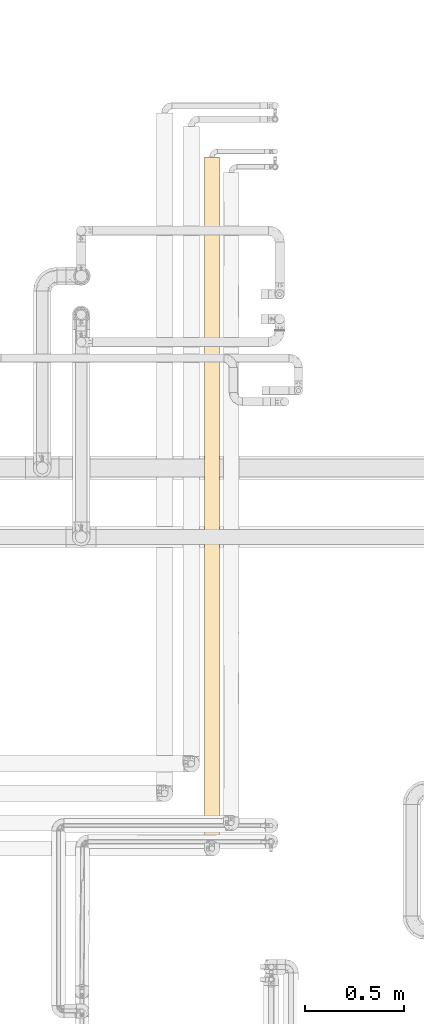
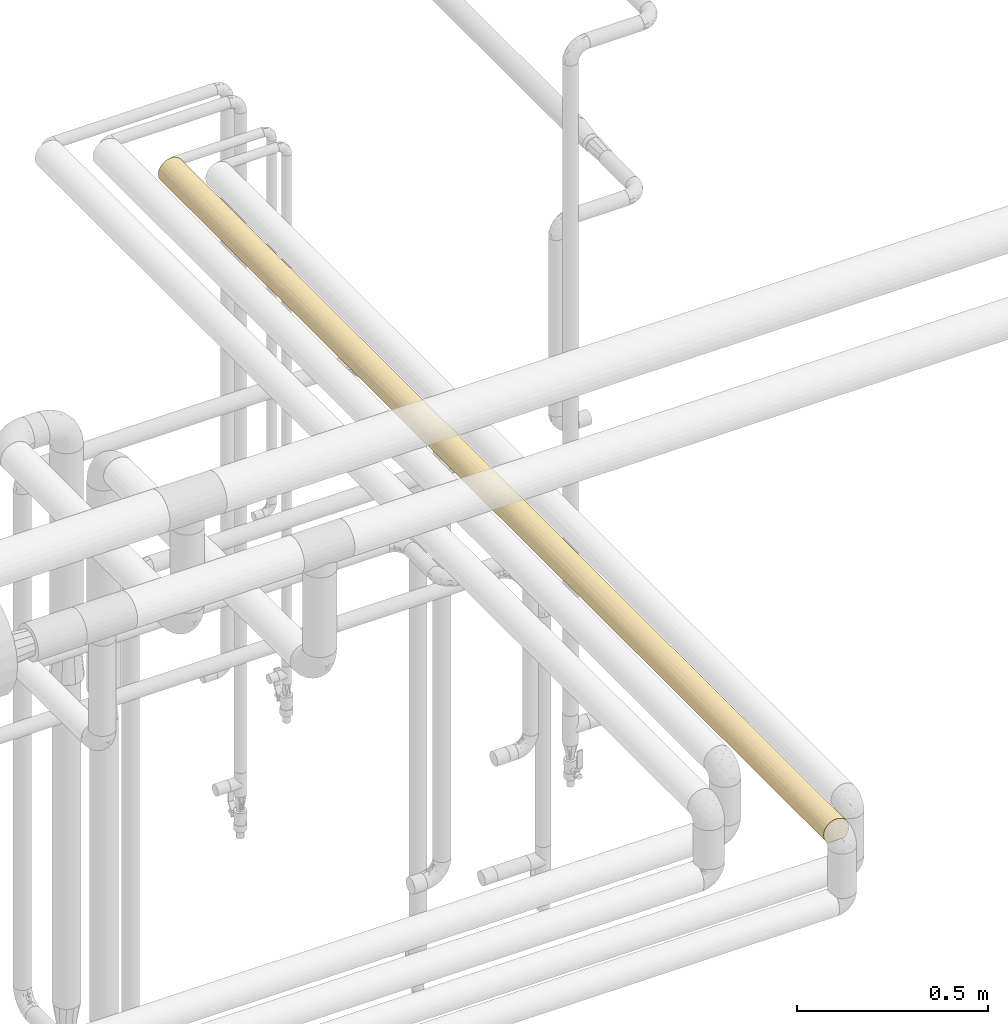
# One storey, part 35 of 827: 1 covering.
"""IFC2X3 building model written with IfcOpenShell, lengths in millimetres."""

from ifc_helpers import new_model, entity, si_unit, converted_unit, derived_unit, direction, frame, origin, place, context, subcontext, project, spatial, faceted_brep, element, save


model = new_model("IFC2X3")

# Units and contexts
model_context = context("Model", 3, precision=0.01, world=origin(), true_north=direction((6.12303176911189e-17, 1.0)))
body_context = subcontext(model_context, "Body", "Model", "MODEL_VIEW")
ifc_project = project(units=[si_unit("LENGTHUNIT", "METRE", prefix="MILLI"), si_unit("AREAUNIT", "SQUARE_METRE"), si_unit("VOLUMEUNIT", "CUBIC_METRE"), converted_unit("PLANEANGLEUNIT", "DEGREE", entity("IfcRatioMeasure", 0.0174532925199433), si_unit("PLANEANGLEUNIT", "RADIAN"), dimensions=[0, 0, 0, 0, 0, 0, 0]), si_unit("MASSUNIT", "GRAM", prefix="KILO"), derived_unit("MASSDENSITYUNIT", [(si_unit("MASSUNIT", "GRAM", prefix="KILO"), 1), (si_unit("LENGTHUNIT", "METRE"), -3)]), derived_unit("MOMENTOFINERTIAUNIT", [(si_unit("LENGTHUNIT", "METRE"), 4)]), si_unit("TIMEUNIT", "SECOND"), si_unit("FREQUENCYUNIT", "HERTZ"), si_unit("THERMODYNAMICTEMPERATUREUNIT", "DEGREE_CELSIUS"), derived_unit("THERMALTRANSMITTANCEUNIT", [(si_unit("MASSUNIT", "GRAM", prefix="KILO"), 1), (si_unit("THERMODYNAMICTEMPERATUREUNIT", "KELVIN"), -1), (si_unit("TIMEUNIT", "SECOND"), -3)]), derived_unit("VOLUMETRICFLOWRATEUNIT", [(si_unit("LENGTHUNIT", "METRE"), 3), (si_unit("TIMEUNIT", "SECOND"), -1)]), derived_unit("MASSFLOWRATEUNIT", [(si_unit("MASSUNIT", "GRAM", prefix="KILO"), 1), (si_unit("TIMEUNIT", "SECOND"), -1)]), derived_unit("ROTATIONALFREQUENCYUNIT", [(si_unit("TIMEUNIT", "SECOND"), -1)]), si_unit("ELECTRICCURRENTUNIT", "AMPERE"), si_unit("ELECTRICVOLTAGEUNIT", "VOLT"), si_unit("POWERUNIT", "WATT"), si_unit("FORCEUNIT", "NEWTON", prefix="KILO"), si_unit("ILLUMINANCEUNIT", "LUX"), si_unit("LUMINOUSFLUXUNIT", "LUMEN"), si_unit("LUMINOUSINTENSITYUNIT", "CANDELA"), derived_unit("USERDEFINED", [(si_unit("MASSUNIT", "GRAM", prefix="KILO"), -1), (si_unit("LENGTHUNIT", "METRE"), -2), (si_unit("TIMEUNIT", "SECOND"), 3), (si_unit("LUMINOUSFLUXUNIT", "LUMEN"), 1)]), derived_unit("LINEARVELOCITYUNIT", [(si_unit("LENGTHUNIT", "METRE"), 1), (si_unit("TIMEUNIT", "SECOND"), -1)]), si_unit("PRESSUREUNIT", "PASCAL"), derived_unit("USERDEFINED", [(si_unit("LENGTHUNIT", "METRE"), -2), (si_unit("MASSUNIT", "GRAM", prefix="KILO"), 1), (si_unit("TIMEUNIT", "SECOND"), -2)]), derived_unit("LINEARFORCEUNIT", [(si_unit("MASSUNIT", "GRAM", prefix="KILO"), 1), (si_unit("LENGTHUNIT", "METRE"), 1), (si_unit("TIMEUNIT", "SECOND"), -2), (si_unit("LENGTHUNIT", "METRE"), -1)]), derived_unit("PLANARFORCEUNIT", [(si_unit("MASSUNIT", "GRAM", prefix="KILO"), 1), (si_unit("LENGTHUNIT", "METRE"), 1), (si_unit("TIMEUNIT", "SECOND"), -2), (si_unit("LENGTHUNIT", "METRE"), -2)])], contexts=[model_context])

# Site, building, storey
site_placement = place(None, origin())
site = spatial("IfcSite", under=ifc_project, at=site_placement, CompositionType="ELEMENT")
building_placement = place(site_placement, origin())
building = spatial("IfcBuilding", under=site, at=building_placement, CompositionType="ELEMENT")
storey_placement = place(building_placement, frame((0.0, 0.0, 28200.0)))
storey = spatial("IfcBuildingStorey", under=building, at=storey_placement, Name="08", CompositionType="ELEMENT", Elevation=28200.0)

# Covering
covering_placement = place(storey_placement, frame((18545.56, 12847.5, 2560.0)))
element("IfcCovering", 1, at=covering_placement, inside=storey, Name=":ADSK_", ObjectType=":ADSK_", PredefinedType="INSULATION", context=body_context, shape_type="Brep", body=[
    faceted_brep([(2.48, 1.6, 31.79), (5.09, 1.6, 23.98), (9.31, 1.6, 16.91), (14.94, 1.6, 10.9), (65.05, 1.6, 10.9), (70.68, 1.6, 16.91), (74.9, 1.6, 23.98), (77.51, 1.6, 31.79), (78.4, 1.6, 40.0), (77.09, 1.6, 49.93), (73.25, 1.6, 59.2), (67.15, 1.6, 67.15), (59.2, 1.6, 73.25), (49.93, 1.6, 77.09), (40.0, 1.6, 78.4), (30.06, 1.6, 77.09), (20.8, 1.6, 73.25), (12.84, 1.6, 67.15), (6.74, 1.6, 59.2), (2.9, 1.6, 49.93), (1.6, 1.6, 40.0), (20.8, 3478.3, 6.74), (12.84, 3478.3, 12.84), (6.74, 3478.3, 20.8), (2.9, 3478.3, 30.06), (1.6, 3478.3, 40.0), (2.9, 3478.3, 49.93), (6.74, 3478.3, 59.2), (12.84, 3478.3, 67.15), (20.8, 3478.3, 73.25), (30.06, 3478.3, 77.09), (40.0, 3478.3, 78.4), (49.93, 3478.3, 77.09), (59.2, 3478.3, 73.25), (67.15, 3478.3, 67.15), (73.25, 3478.3, 59.2), (77.09, 3478.3, 49.93), (78.4, 3478.3, 40.0), (77.09, 3478.3, 30.06), (73.25, 3478.3, 20.8), (67.15, 3478.3, 12.84), (59.2, 3478.3, 6.74), (49.93, 3478.3, 2.9), (40.0, 3478.3, 1.6), (30.06, 3478.3, 2.9), (9.53, 3219.11, 16.62), (3.58, 287.23, 27.82), (7.01, 218.66, 20.33), (9.53, 2754.64, 16.62), (17.76, 2708.4, 8.69), (17.36, 2482.89, 8.98), (2.29, 3153.74, 32.71), (2.42, 2856.65, 32.07), (1.6, 3045.56, 40.0), (11.96, 287.24, 13.75), (27.09, 1963.43, 3.83), (28.96, 2162.99, 3.21), (32.97, 1853.13, 2.24), (7.01, 485.18, 20.33), (15.06, 491.88, 10.8), (25.3, 3233.25, 4.52), (11.39, 914.92, 14.37), (10.86, 658.66, 14.98), (6.04, 783.02, 22.06), (3.89, 3283.65, 26.92), (4.52, 3072.98, 25.3), (22.88, 606.06, 5.62), (23.76, 835.17, 5.2), (29.53, 688.07, 3.05), (2.85, 616.82, 30.25), (1.6, 217.97, 40.0), (40.0, 3261.93, 1.6), (40.0, 660.01, 1.6), (40.0, 443.64, 1.6), (40.0, 876.39, 1.6), (23.31, 384.99, 5.41), (26.63, 8.5, 4.0), (20.48, 5.57, 6.92), (24.03, 2447.85, 5.07), (32.57, 2467.59, 2.32), (32.19, 1223.7, 2.4), (40.0, 1093.44, 1.6), (28.94, 1001.34, 3.22), (32.71, 3153.74, 2.29), (25.3, 2948.59, 4.52), (31.75, 335.45, 2.49), (33.21, 10.29, 2.2), (17.51, 298.24, 8.87), (16.62, 3154.03, 9.53), (4.86, 2721.19, 24.5), (40.0, 227.27, 1.6), (40.0, 10.9, 1.6), (33.12, 2916.66, 2.22), (28.05, 2689.88, 3.5), (1.6, 3261.93, 40.0), (1.6, 434.34, 40.0), (17.38, 2931.84, 8.96), (7.28, 2941.54, 19.89), (11.76, 2986.88, 13.97), (2.9, 953.6, 30.08), (1.6, 1083.46, 40.0), (3.06, 1262.09, 29.49), (2.54, 2622.2, 31.51), (25.08, 1521.26, 4.61), (32.66, 1590.99, 2.3), (17.22, 717.19, 9.08), (6.49, 1362.64, 21.23), (3.48, 1624.39, 28.11), (6.45, 1670.45, 21.3), (6.41, 1085.46, 21.37), (12.45, 1245.73, 13.24), (1.6, 867.09, 40.0), (1.6, 650.71, 40.0), (40.0, 2612.81, 1.6), (40.0, 3045.56, 1.6), (40.0, 2829.18, 1.6), (40.0, 1961.65, 1.6), (22.04, 2116.57, 6.05), (12.14, 2378.34, 13.56), (16.28, 2019.25, 9.79), (9.05, 1840.27, 17.25), (9.42, 2122.62, 16.76), (7.4, 2369.94, 19.69), (15.3, 1744.72, 10.59), (2.38, 2282.72, 32.28), (4.17, 2451.09, 26.17), (4.68, 2224.01, 24.92), (2.29, 2025.52, 32.71), (1.6, 2172.7, 40.0), (25.96, 1758.89, 4.25), (1.6, 2392.75, 40.0), (1.6, 2396.44, 40.0), (1.6, 2612.81, 40.0), (1.6, 2829.18, 40.0), (1.6, 1516.21, 40.0), (40.0, 2395.76, 1.6), (40.0, 2395.08, 1.6), (40.0, 2178.71, 1.6), (40.0, 1959.61, 1.6), (40.0, 1744.6, 1.6), (24.44, 1282.91, 4.89), (18.12, 1234.93, 8.44), (17.51, 1479.79, 8.87), (1.6, 1527.26, 40.0), (1.6, 1732.58, 40.0), (1.6, 1087.14, 40.0), (1.6, 1299.83, 40.0), (1.6, 1307.2, 40.0), (19.12, 1023.05, 7.77), (10.19, 1564.74, 15.79), (3.17, 1838.1, 29.1), (1.6, 1747.32, 40.0), (1.6, 1952.64, 40.0), (4.96, 1994.53, 24.27), (1.6, 2180.06, 40.0), (1.6, 1963.69, 40.0), (40.0, 2177.35, 1.6), (40.0, 1741.88, 1.6), (40.0, 1527.55, 1.6), (40.0, 1525.51, 1.6), (40.0, 1310.49, 1.6), (40.0, 1092.76, 1.6), (40.0, 1309.13, 1.6), (75.47, 3233.25, 25.3), (50.46, 688.07, 3.05), (51.05, 1001.34, 3.22), (56.23, 835.17, 5.2), (63.37, 3219.11, 9.53), (72.98, 218.66, 20.33), (72.98, 485.18, 20.33), (69.13, 658.66, 14.98), (73.95, 783.02, 22.06), (76.06, 1504.87, 26.81), (76.79, 1232.32, 29.01), (73.89, 1322.89, 21.95), (56.19, 2734.63, 5.18), (60.1, 2941.54, 7.28), (63.37, 2754.64, 9.53), (47.79, 1755.35, 2.39), (58.31, 1653.16, 6.24), (48.53, 1529.81, 2.56), (77.09, 953.6, 30.08), (77.14, 616.82, 30.25), (53.36, 8.5, 4.0), (56.68, 384.99, 5.41), (59.51, 5.57, 6.92), (47.28, 3153.74, 2.29), (53.07, 3283.65, 3.89), (54.69, 3072.98, 4.52), (62.48, 298.24, 8.87), (64.93, 491.88, 10.8), (51.09, 1959.61, 3.23), (76.41, 287.23, 27.82), (78.4, 217.97, 40.0), (68.03, 287.24, 13.75), (78.4, 434.34, 40.0), (47.95, 1299.31, 2.43), (78.4, 3261.93, 40.0), (70.46, 3154.03, 16.62), (48.24, 335.45, 2.49), (73.85, 2357.65, 21.86), (77.47, 2351.15, 31.59), (75.94, 2184.07, 26.49), (46.78, 10.29, 2.2), (77.7, 3153.74, 32.71), (75.47, 2948.59, 25.3), (77.77, 2916.66, 33.12), (76.4, 2628.79, 27.78), (47.92, 2856.65, 2.42), (62.77, 717.19, 9.08), (71.39, 2911.18, 17.89), (66.03, 2986.88, 11.76), (57.11, 606.06, 5.62), (73.58, 1085.46, 21.37), (55.55, 1282.91, 4.89), (60.87, 1023.05, 7.77), (65.04, 2374.99, 10.88), (60.59, 2543.84, 7.58), (62.89, 1287.66, 9.16), (71.12, 2658.69, 17.51), (72.41, 1550.07, 19.41), (78.4, 867.09, 40.0), (78.4, 650.71, 40.0), (78.4, 2612.81, 40.0), (78.4, 2394.6, 40.0), (78.4, 2176.38, 40.0), (70.02, 2445.87, 16.06), (78.4, 3045.56, 40.0), (78.4, 2829.18, 40.0), (75.02, 1733.96, 24.25), (77.55, 1687.24, 31.96), (76.21, 1958.17, 27.23), (78.4, 1958.16, 40.0), (71.04, 2043.08, 17.4), (78.4, 1085.3, 40.0), (68.6, 914.92, 14.37), (69.04, 2236.21, 14.88), (49.29, 2255.0, 2.74), (58.21, 2308.63, 6.19), (53.47, 2506.5, 4.04), (46.33, 2503.95, 2.12), (67.71, 1448.01, 13.42), (67.56, 1749.85, 13.26), (78.4, 1521.73, 40.0), (77.83, 1412.63, 33.45), (68.57, 1182.68, 14.34), (77.77, 2089.89, 33.07), (78.4, 1303.52, 40.0), (56.77, 2092.81, 5.45), (57.65, 1873.89, 5.9), (63.06, 1997.32, 9.29), (78.4, 1739.95, 40.0), (70.46, 3219.11, 63.37), (77.77, 563.24, 46.88), (76.39, 860.24, 52.25), (75.47, 531.31, 54.69), (63.37, 3154.03, 70.46), (40.0, 3261.93, 78.4), (40.0, 217.97, 78.4), (54.69, 3233.25, 75.47), (77.7, 3153.74, 47.28), (76.1, 3283.65, 53.07), (75.47, 3072.98, 54.69), (70.46, 325.87, 63.37), (63.37, 260.79, 70.46), (53.07, 196.25, 76.1), (47.28, 326.15, 77.7), (54.69, 406.92, 75.47), (47.28, 3153.74, 77.7), (54.69, 2948.59, 75.47), (75.47, 246.65, 54.69), (52.25, 2619.66, 76.39), (62.54, 2650.14, 71.08), (67.79, 2575.76, 66.49), (71.86, 2488.45, 61.42), (70.46, 2754.64, 63.37), (66.49, 904.5, 67.79), (61.37, 990.94, 71.9), (63.37, 725.25, 70.46), (65.0, 1965.36, 69.14), (69.85, 2026.98, 64.15), (66.21, 2170.84, 68.06), (74.92, 2730.06, 55.95), (72.71, 2941.54, 60.1), (71.08, 829.75, 62.54), (46.88, 2916.66, 77.77), (77.7, 326.15, 47.28), (77.57, 2856.65, 47.92), (47.92, 623.25, 77.57), (40.0, 434.34, 78.4), (55.95, 749.92, 74.92), (60.1, 538.36, 72.71), (62.1, 2911.18, 71.39), (68.23, 2986.88, 66.03), (71.39, 568.72, 62.1), (66.03, 493.02, 68.23), (48.75, 2338.65, 77.38), (40.0, 2612.81, 78.4), (40.0, 2396.44, 78.4), (40.0, 2394.6, 78.4), (40.0, 2180.07, 78.4), (77.39, 1141.87, 48.72), (76.69, 1822.27, 51.32), (72.76, 1621.01, 60.02), (77.06, 1483.03, 50.04), (59.05, 2097.14, 73.33), (52.45, 1963.69, 76.32), (77.4, 2285.49, 48.7), (68.1, 1743.43, 66.17), (72.59, 1867.32, 60.3), (55.02, 999.61, 75.33), (58.53, 1374.62, 73.63), (49.53, 1349.16, 77.19), (40.0, 3045.56, 78.4), (40.0, 2829.18, 78.4), (58.44, 2344.33, 73.68), (61.69, 1672.53, 71.68), (51.19, 1625.54, 76.73), (68.34, 2362.52, 65.9), (58.91, 1874.31, 73.42), (73.6, 2106.91, 58.57), (75.29, 2480.17, 55.13), (67.22, 1433.32, 67.08), (65.87, 1117.88, 68.37), (74.18, 1384.52, 57.49), (77.71, 2039.81, 47.2), (77.67, 2518.07, 47.43), (73.68, 1135.57, 58.44), (47.22, 977.12, 77.71), (40.0, 867.09, 78.4), (40.0, 1087.14, 78.4), (40.0, 1085.3, 78.4), (40.0, 650.71, 78.4), (40.0, 2176.38, 78.4), (40.0, 1963.69, 78.4), (40.0, 1958.17, 78.4), (40.0, 1747.32, 78.4), (40.0, 1527.26, 78.4), (40.0, 1521.73, 78.4), (40.0, 1307.2, 78.4), (40.0, 1303.52, 78.4), (40.0, 1739.95, 78.4), (16.62, 3219.11, 70.46), (33.12, 563.24, 77.77), (27.74, 860.24, 76.39), (25.3, 531.31, 75.47), (9.53, 3154.03, 63.37), (4.52, 3233.25, 54.69), (32.71, 3153.74, 77.7), (26.92, 3283.65, 76.1), (25.3, 3072.98, 75.47), (16.62, 325.87, 70.46), (9.53, 260.79, 63.37), (3.89, 196.25, 53.07), (2.29, 326.15, 47.28), (4.52, 406.92, 54.69), (2.29, 3153.74, 47.28), (4.52, 2948.59, 54.69), (25.3, 246.65, 75.47), (3.6, 2619.66, 52.25), (8.91, 2650.14, 62.54), (13.5, 2575.76, 67.79), (18.57, 2488.45, 71.86), (16.62, 2754.64, 70.46), (12.2, 904.5, 66.49), (8.09, 990.94, 61.37), (9.53, 725.25, 63.37), (10.86, 1965.36, 65.0), (15.84, 2026.98, 69.85), (11.93, 2170.84, 66.21), (24.04, 2730.06, 74.92), (19.89, 2941.54, 72.71), (17.45, 829.75, 71.08), (2.22, 2916.66, 46.88), (32.71, 326.15, 77.7), (32.07, 2856.65, 77.57), (2.42, 623.25, 47.92), (5.07, 749.92, 55.95), (7.28, 538.36, 60.1), (8.6, 2911.18, 62.1), (13.97, 2986.88, 68.23), (17.89, 568.72, 71.39), (11.76, 493.02, 66.03), (2.61, 2338.65, 48.75), (31.27, 1141.87, 77.39), (28.67, 1822.27, 76.69), (19.97, 1621.01, 72.76), (29.96, 1483.03, 77.06), (6.66, 2097.14, 59.05), (3.67, 1963.69, 52.45), (31.29, 2285.49, 77.4), (13.82, 1743.43, 68.1), (19.69, 1867.32, 72.59), (4.66, 999.61, 55.02), (6.36, 1374.62, 58.53), (2.8, 1349.16, 49.53), (6.32, 2344.33, 58.44), (8.31, 1672.53, 61.69), (3.26, 1625.54, 51.19), (14.09, 2362.52, 68.34), (6.58, 1874.31, 58.91), (21.42, 2106.91, 73.6), (24.86, 2480.17, 75.29), (12.91, 1433.32, 67.22), (11.62, 1117.88, 65.87), (22.5, 1384.52, 74.18), (32.79, 2039.81, 77.71), (32.56, 2518.07, 77.67), (21.55, 1135.57, 73.68), (2.28, 977.12, 47.22)], [[[0, 1, 2, 3, 4, 5, 6, 7, 8, 9, 10, 11, 12, 13, 14, 15, 16, 17, 18, 19, 20]], [[21, 22, 23, 24, 25, 26, 27, 28, 29, 30, 31, 32, 33, 34, 35, 36, 37, 38, 39, 40, 41, 42, 43, 44]], [[22, 45, 23]], [[46, 47, 1]], [[48, 49, 50]], [[51, 52, 53]], [[54, 2, 47]], [[55, 56, 57]], [[54, 58, 59]], [[44, 60, 21]], [[61, 62, 63]], [[51, 64, 65]], [[66, 67, 68]], [[58, 62, 59]], [[58, 69, 63]], [[0, 20, 70]], [[54, 3, 2]], [[44, 43, 71]], [[72, 73, 68, 74]], [[75, 76, 77]], [[78, 79, 56]], [[80, 81, 82]], [[60, 83, 84]], [[47, 58, 54]], [[85, 68, 73]], [[86, 76, 85]], [[3, 54, 87]], [[21, 60, 88]], [[58, 46, 69]], [[52, 65, 89]], [[90, 91, 86]], [[46, 1, 0]], [[84, 92, 93]], [[21, 88, 22]], [[45, 22, 88]], [[24, 64, 51]], [[24, 51, 94]], [[85, 76, 75]], [[73, 90, 85]], [[54, 59, 87]], [[46, 70, 95]], [[69, 46, 95]], [[96, 49, 48]], [[84, 83, 92]], [[97, 45, 98]], [[99, 100, 101]], [[52, 89, 102]], [[86, 85, 90]], [[85, 75, 68]], [[75, 66, 68]], [[103, 104, 80]], [[61, 105, 62]], [[106, 107, 108]], [[109, 110, 61]], [[93, 49, 84]], [[111, 69, 95, 112]], [[63, 99, 109]], [[98, 45, 88]], [[0, 70, 46]], [[64, 45, 65]], [[71, 83, 44]], [[88, 60, 84]], [[113, 79, 93]], [[50, 49, 78]], [[83, 71, 114]], [[83, 114, 92]], [[44, 83, 60]], [[93, 115, 113]], [[57, 56, 116]], [[92, 115, 93]], [[49, 93, 78]], [[117, 118, 50]], [[98, 96, 48]], [[119, 120, 121]], [[118, 122, 48]], [[119, 123, 120]], [[124, 102, 125]], [[122, 121, 126]], [[127, 128, 124]], [[103, 123, 129]], [[102, 130, 131, 132, 133]], [[107, 101, 134]], [[93, 79, 78]], [[79, 113, 135, 136, 137]], [[56, 79, 137]], [[57, 116, 138, 139]], [[117, 56, 55]], [[129, 57, 104]], [[140, 141, 142]], [[92, 114, 115]], [[94, 51, 53]], [[94, 25, 24]], [[52, 51, 65]], [[97, 89, 65]], [[102, 133, 52]], [[24, 23, 64]], [[45, 64, 23]], [[82, 68, 67]], [[69, 111, 99]], [[63, 109, 61]], [[69, 99, 63]], [[107, 134, 143, 144]], [[101, 100, 145, 146, 147, 134]], [[109, 99, 101]], [[106, 109, 101]], [[109, 106, 110]], [[148, 105, 61]], [[142, 110, 149]], [[148, 141, 140]], [[110, 148, 61]], [[148, 140, 82]], [[80, 82, 140]], [[74, 68, 82]], [[150, 144, 151, 152]], [[108, 150, 153]], [[123, 142, 149]], [[104, 103, 129]], [[120, 123, 149]], [[129, 123, 119]], [[108, 120, 149]], [[120, 153, 121]], [[153, 127, 126]], [[119, 121, 118]], [[107, 106, 101]], [[110, 106, 149]], [[62, 105, 59]], [[63, 62, 58]], [[66, 59, 105]], [[87, 59, 75]], [[75, 77, 87]], [[3, 87, 77]], [[98, 88, 96]], [[97, 98, 48]], [[88, 84, 96]], [[84, 49, 96]], [[97, 48, 89]], [[45, 97, 65]], [[122, 89, 48]], [[102, 89, 125]], [[130, 102, 124]], [[99, 111, 100]], [[124, 128, 154, 130]], [[126, 124, 125]], [[124, 126, 127]], [[150, 127, 153]], [[150, 152, 127]], [[122, 126, 125]], [[121, 153, 126]], [[122, 125, 89]], [[121, 122, 118]], [[108, 153, 120]], [[127, 152, 155, 128]], [[144, 150, 107]], [[56, 137, 156, 116]], [[104, 57, 139]], [[57, 129, 55]], [[104, 139, 157, 158, 159, 160]], [[104, 160, 80]], [[140, 142, 103]], [[123, 103, 142]], [[129, 119, 55]], [[117, 55, 119]], [[118, 117, 119]], [[78, 56, 117]], [[1, 47, 2]], [[58, 47, 46]], [[59, 66, 75]], [[67, 105, 148]], [[105, 67, 66]], [[148, 82, 67]], [[117, 50, 78]], [[48, 50, 118]], [[133, 53, 52]], [[148, 110, 141]], [[142, 141, 110]], [[80, 140, 103]], [[82, 81, 161, 74]], [[80, 160, 162, 81]], [[106, 108, 149]], [[150, 108, 107]], [[38, 163, 39]], [[164, 165, 166]], [[41, 40, 167]], [[168, 6, 5]], [[169, 170, 171]], [[172, 173, 174]], [[175, 176, 177]], [[178, 179, 180]], [[181, 182, 171]], [[183, 184, 185]], [[186, 187, 188]], [[189, 184, 190]], [[178, 138, 191]], [[192, 193, 7]], [[42, 187, 186]], [[6, 192, 7]], [[5, 194, 168]], [[4, 194, 5]], [[192, 182, 195]], [[165, 161, 196]], [[38, 37, 197]], [[39, 163, 198]], [[169, 190, 170]], [[73, 199, 90]], [[192, 168, 169]], [[199, 164, 184]], [[200, 201, 202]], [[90, 199, 203]], [[183, 203, 199]], [[163, 204, 205]], [[206, 207, 205]], [[39, 198, 40]], [[198, 167, 40]], [[186, 208, 114]], [[42, 71, 43]], [[189, 4, 185]], [[170, 190, 209]], [[182, 192, 169]], [[7, 193, 8]], [[198, 210, 211]], [[205, 204, 206]], [[176, 167, 211]], [[203, 91, 90]], [[164, 166, 212]], [[181, 213, 173]], [[164, 73, 72, 74]], [[199, 184, 183]], [[165, 214, 215]], [[212, 184, 164]], [[216, 217, 177]], [[214, 218, 215]], [[207, 219, 205]], [[174, 220, 172]], [[171, 182, 169]], [[182, 221, 222, 195]], [[201, 223, 224, 225]], [[226, 177, 219]], [[211, 167, 198]], [[195, 193, 192]], [[187, 167, 188]], [[197, 204, 38]], [[198, 163, 205]], [[204, 197, 227]], [[204, 227, 206]], [[38, 204, 163]], [[206, 227, 228, 223]], [[207, 200, 219]], [[206, 223, 207]], [[207, 201, 200]], [[229, 230, 172]], [[230, 231, 232]], [[229, 233, 231]], [[173, 234, 181]], [[235, 213, 171]], [[236, 216, 226]], [[211, 210, 177]], [[200, 226, 219]], [[156, 237, 191]], [[217, 238, 239]], [[237, 136, 240]], [[240, 208, 239]], [[241, 218, 179]], [[229, 242, 233]], [[230, 243, 244]], [[223, 201, 207]], [[236, 200, 233]], [[42, 186, 71]], [[114, 71, 186]], [[208, 186, 188]], [[176, 175, 188]], [[208, 113, 115, 114]], [[42, 41, 187]], [[167, 187, 41]], [[196, 159, 180]], [[235, 170, 209]], [[181, 171, 213]], [[215, 235, 209]], [[245, 213, 235]], [[209, 212, 166]], [[245, 218, 241]], [[164, 74, 165]], [[196, 161, 81, 162, 160, 159]], [[174, 173, 213]], [[231, 202, 246]], [[173, 244, 247]], [[248, 249, 191]], [[238, 237, 239]], [[178, 249, 179]], [[249, 242, 179]], [[180, 179, 214]], [[215, 245, 235]], [[174, 245, 241]], [[215, 218, 245]], [[179, 218, 214]], [[171, 170, 235]], [[190, 169, 194]], [[189, 190, 194]], [[212, 190, 184]], [[4, 189, 194]], [[185, 184, 189]], [[196, 180, 214]], [[180, 159, 178]], [[198, 205, 210]], [[176, 211, 177]], [[205, 219, 210]], [[177, 210, 219]], [[217, 175, 177]], [[167, 176, 188]], [[239, 208, 175]], [[188, 175, 208]], [[245, 174, 213]], [[220, 174, 241]], [[242, 220, 241]], [[229, 172, 220]], [[179, 242, 241]], [[242, 250, 233]], [[236, 250, 216]], [[202, 233, 200]], [[229, 220, 242]], [[246, 232, 231]], [[231, 230, 229]], [[243, 247, 244]], [[230, 232, 251, 243]], [[173, 172, 244]], [[230, 244, 172]], [[169, 168, 194]], [[6, 168, 192]], [[73, 164, 199]], [[190, 212, 209]], [[165, 215, 166]], [[209, 166, 215]], [[221, 182, 181]], [[177, 226, 216]], [[200, 236, 226]], [[250, 236, 233]], [[238, 217, 216]], [[175, 217, 239]], [[216, 250, 238]], [[250, 249, 248]], [[237, 238, 248]], [[240, 136, 135, 113]], [[237, 156, 137, 136]], [[208, 240, 113]], [[237, 240, 239]], [[246, 201, 225]], [[233, 202, 231]], [[201, 246, 202]], [[232, 246, 225]], [[165, 74, 161]], [[234, 173, 247]], [[234, 221, 181]], [[191, 138, 116, 156]], [[242, 249, 250]], [[237, 248, 191]], [[250, 248, 238]], [[165, 196, 214]], [[178, 159, 158, 157, 139, 138]], [[178, 191, 249]], [[252, 35, 34]], [[253, 254, 255]], [[33, 256, 34]], [[32, 31, 257]], [[13, 258, 14]], [[32, 259, 33]], [[260, 261, 262]], [[263, 264, 11]], [[36, 261, 260]], [[13, 265, 266]], [[266, 265, 267]], [[259, 268, 269]], [[10, 263, 11]], [[12, 11, 264]], [[10, 270, 263]], [[271, 272, 269]], [[10, 9, 270]], [[273, 274, 275]], [[272, 273, 275]], [[276, 277, 278]], [[279, 280, 281]], [[282, 283, 275]], [[9, 8, 193]], [[36, 197, 37]], [[33, 259, 256]], [[254, 284, 255]], [[285, 271, 269]], [[270, 286, 255]], [[256, 252, 34]], [[260, 287, 227]], [[266, 288, 289]], [[290, 291, 278]], [[256, 292, 293]], [[269, 268, 285]], [[283, 252, 293]], [[263, 294, 295]], [[255, 286, 253]], [[291, 264, 295]], [[296, 297, 298, 299, 300]], [[284, 276, 278]], [[301, 221, 234, 247]], [[302, 303, 304]], [[305, 296, 306]], [[307, 225, 224]], [[280, 308, 309]], [[310, 311, 312]], [[293, 252, 256]], [[261, 252, 262]], [[295, 264, 263]], [[265, 264, 267]], [[257, 268, 32]], [[256, 259, 269]], [[193, 286, 9]], [[263, 270, 255]], [[268, 257, 313]], [[268, 313, 285]], [[32, 268, 259]], [[285, 313, 314, 297]], [[271, 315, 272]], [[285, 297, 271]], [[271, 296, 315]], [[311, 316, 317]], [[300, 306, 296]], [[280, 318, 281]], [[318, 272, 315]], [[293, 292, 275]], [[305, 306, 319]], [[320, 321, 274]], [[311, 322, 316]], [[311, 323, 322]], [[322, 303, 308]], [[324, 301, 304]], [[225, 307, 325]], [[223, 326, 224]], [[286, 193, 195]], [[307, 326, 321]], [[286, 195, 253]], [[9, 286, 270]], [[253, 195, 222, 221]], [[254, 327, 284]], [[253, 221, 254]], [[324, 304, 303]], [[254, 301, 327]], [[323, 284, 327]], [[295, 294, 278]], [[327, 324, 322]], [[311, 310, 277]], [[317, 312, 311]], [[288, 328, 329]], [[36, 260, 197]], [[328, 330, 331, 329]], [[227, 197, 260]], [[287, 260, 262]], [[283, 282, 262]], [[287, 223, 228, 227]], [[36, 35, 261]], [[252, 261, 35]], [[13, 266, 258]], [[289, 258, 266]], [[288, 266, 267]], [[291, 290, 267]], [[288, 329, 332, 289]], [[13, 12, 265]], [[264, 265, 12]], [[221, 301, 254]], [[306, 300, 333, 334, 335, 336]], [[322, 324, 303]], [[301, 247, 304]], [[251, 304, 247, 243]], [[304, 251, 302]], [[302, 232, 325]], [[309, 302, 320]], [[327, 322, 323]], [[316, 308, 279]], [[319, 279, 305]], [[316, 319, 317]], [[336, 317, 306]], [[312, 337, 338, 339, 340, 330]], [[256, 269, 292]], [[283, 293, 275]], [[269, 272, 292]], [[275, 292, 272]], [[274, 282, 275]], [[252, 283, 262]], [[326, 282, 321]], [[262, 282, 287]], [[263, 255, 294]], [[291, 295, 278]], [[255, 284, 294]], [[278, 294, 284]], [[277, 290, 278]], [[264, 291, 267]], [[328, 290, 310]], [[267, 290, 288]], [[312, 317, 337]], [[288, 290, 328]], [[330, 328, 312]], [[312, 328, 310]], [[322, 308, 316]], [[309, 308, 303]], [[302, 309, 303]], [[280, 309, 320]], [[318, 280, 320]], [[308, 280, 279]], [[318, 315, 281]], [[305, 281, 315]], [[272, 318, 273]], [[274, 273, 318]], [[320, 274, 318]], [[274, 321, 282]], [[281, 305, 279]], [[296, 305, 315]], [[317, 319, 306]], [[279, 319, 316]], [[287, 282, 326]], [[321, 320, 307]], [[325, 320, 302]], [[320, 325, 307]], [[224, 326, 307]], [[232, 302, 251]], [[232, 225, 325]], [[287, 326, 223]], [[284, 323, 276]], [[277, 276, 323]], [[311, 277, 323]], [[277, 310, 290]], [[297, 296, 271]], [[301, 324, 327]], [[317, 336, 341, 337]], [[342, 29, 28]], [[343, 344, 345]], [[27, 346, 28]], [[26, 25, 94]], [[19, 70, 20]], [[26, 347, 27]], [[348, 349, 350]], [[351, 352, 17]], [[30, 349, 348]], [[19, 353, 354]], [[354, 353, 355]], [[347, 356, 357]], [[16, 351, 17]], [[18, 17, 352]], [[16, 358, 351]], [[359, 360, 357]], [[16, 15, 358]], [[361, 362, 363]], [[360, 361, 363]], [[364, 365, 366]], [[367, 368, 369]], [[370, 371, 363]], [[15, 14, 258]], [[30, 257, 31]], [[27, 347, 346]], [[344, 372, 345]], [[373, 359, 357]], [[358, 374, 345]], [[346, 342, 28]], [[348, 375, 313]], [[354, 376, 95]], [[377, 378, 366]], [[346, 379, 380]], [[357, 356, 373]], [[371, 342, 380]], [[351, 381, 382]], [[345, 374, 343]], [[378, 352, 382]], [[383, 132, 131, 130, 154]], [[372, 364, 366]], [[384, 329, 331, 330, 340]], [[385, 386, 387]], [[388, 383, 389]], [[390, 333, 300, 299]], [[368, 391, 392]], [[393, 394, 395]], [[380, 342, 346]], [[349, 342, 350]], [[382, 352, 351]], [[353, 352, 355]], [[94, 356, 26]], [[346, 347, 357]], [[258, 374, 15]], [[351, 358, 345]], [[356, 94, 53]], [[356, 53, 373]], [[26, 356, 347]], [[373, 53, 133, 132]], [[359, 396, 360]], [[373, 132, 359]], [[359, 383, 396]], [[394, 397, 398]], [[151, 398, 389]], [[368, 399, 369]], [[399, 360, 396]], [[380, 379, 363]], [[388, 389, 400]], [[401, 402, 362]], [[394, 403, 397]], [[394, 404, 403]], [[403, 386, 391]], [[405, 384, 387]], [[333, 390, 406]], [[407, 299, 298, 297]], [[374, 258, 289]], [[390, 407, 402]], [[374, 289, 343]], [[15, 374, 358]], [[343, 289, 332, 329]], [[344, 408, 372]], [[343, 329, 344]], [[405, 387, 386]], [[344, 384, 408]], [[404, 372, 408]], [[382, 381, 366]], [[408, 405, 403]], [[394, 393, 365]], [[398, 395, 394]], [[376, 409, 111]], [[30, 348, 257]], [[409, 145, 100, 111]], [[313, 257, 348]], [[375, 348, 350]], [[371, 370, 350]], [[375, 297, 314, 313]], [[30, 29, 349]], [[342, 349, 29]], [[19, 354, 70]], [[95, 70, 354]], [[376, 354, 355]], [[378, 377, 355]], [[376, 111, 112, 95]], [[19, 18, 353]], [[352, 353, 18]], [[329, 384, 344]], [[360, 399, 361]], [[403, 405, 386]], [[384, 340, 387]], [[387, 340, 339, 338, 337, 341]], [[387, 341, 385]], [[385, 335, 406]], [[392, 385, 401]], [[408, 403, 404]], [[397, 391, 367]], [[400, 367, 388]], [[397, 400, 398]], [[389, 154, 128, 155, 152, 151]], [[395, 143, 134, 147, 146, 145]], [[346, 357, 379]], [[371, 380, 363]], [[357, 360, 379]], [[363, 379, 360]], [[362, 370, 363]], [[342, 371, 350]], [[407, 370, 402]], [[350, 370, 375]], [[351, 345, 381]], [[378, 382, 366]], [[345, 372, 381]], [[366, 381, 372]], [[365, 377, 366]], [[352, 378, 355]], [[409, 377, 393]], [[355, 377, 376]], [[395, 398, 143]], [[376, 377, 409]], [[145, 409, 395]], [[395, 409, 393]], [[403, 391, 397]], [[392, 391, 386]], [[385, 392, 386]], [[368, 392, 401]], [[399, 368, 401]], [[391, 368, 367]], [[399, 396, 369]], [[388, 369, 396]], [[154, 389, 383]], [[362, 361, 399]], [[401, 362, 399]], [[362, 402, 370]], [[369, 388, 367]], [[383, 388, 396]], [[398, 400, 389]], [[367, 400, 397]], [[375, 370, 407]], [[402, 401, 390]], [[406, 401, 385]], [[401, 406, 390]], [[299, 407, 390]], [[385, 341, 336, 335]], [[406, 335, 334, 333]], [[375, 407, 297]], [[372, 404, 364]], [[365, 364, 404]], [[394, 365, 404]], [[365, 393, 377]], [[132, 383, 359]], [[384, 405, 408]], [[398, 151, 144, 143]], [[77, 76, 86, 91, 203, 183, 185, 4, 3]]]),
])

save(model, "model.ifc")
